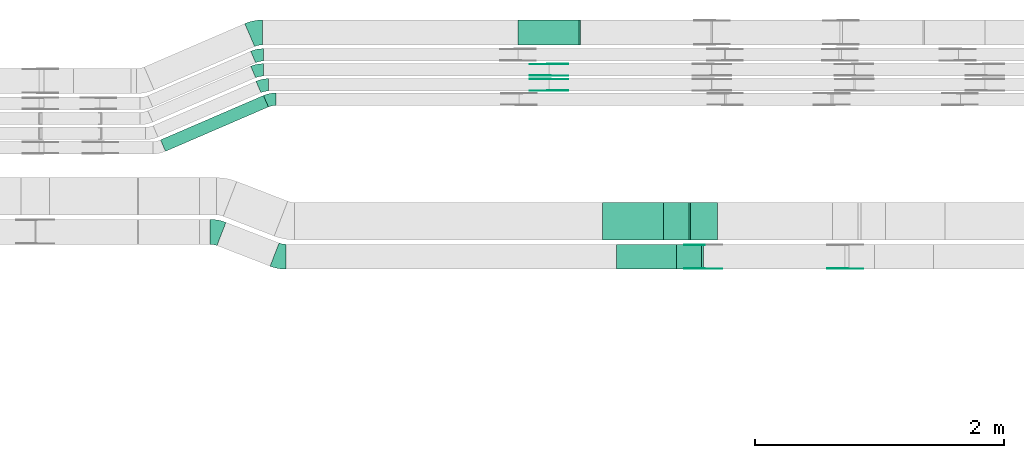
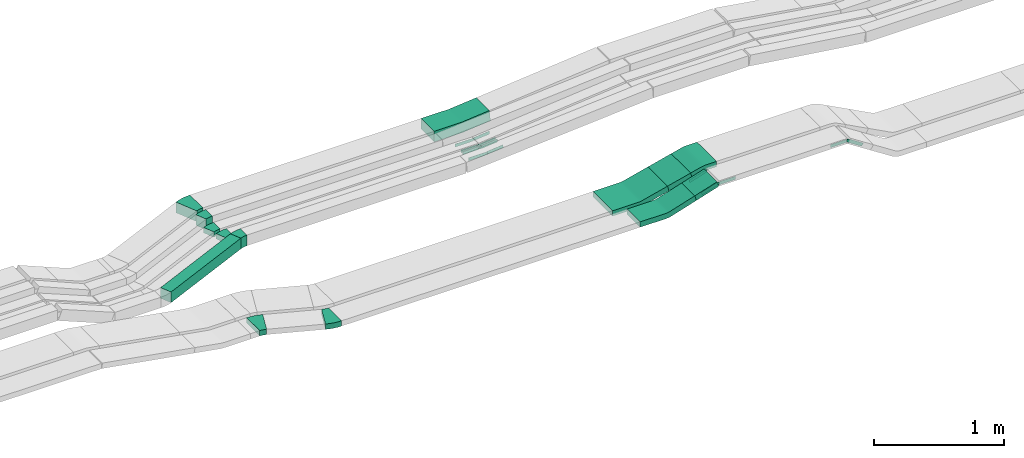
# One storey, part 18 of 31: 24 flow fittings, 3 flow segments.
"""IFC2X3 building model written with IfcOpenShell, lengths in millimetres."""

from ifc_helpers import new_model, entity, si_unit, converted_unit, derived_unit, direction, frame, frame_2d, origin, origin_2d_with_axis, place, context, subcontext, project, spatial, polyline, circle_curve, parameter, trimmed, segment, composite_curve, rectangle, outline, extrude, source, transform, mapped, material, type_object, type_shapes, element, save


model = new_model("IFC2X3")

# Units and contexts
model_context = context("Model", 3, precision=0.01, world=origin(), true_north=direction((6.12303176911189e-17, 1.0)))
body_context = subcontext(model_context, "Body", "Model", "MODEL_VIEW")
ifc_project = project(units=[si_unit("LENGTHUNIT", "METRE", prefix="MILLI"), si_unit("AREAUNIT", "SQUARE_METRE"), si_unit("VOLUMEUNIT", "CUBIC_METRE"), converted_unit("PLANEANGLEUNIT", "DEGREE", entity("IfcRatioMeasure", 0.0174532925199433), si_unit("PLANEANGLEUNIT", "RADIAN"), dimensions=[0, 0, 0, 0, 0, 0, 0]), si_unit("MASSUNIT", "GRAM", prefix="KILO"), derived_unit("MASSDENSITYUNIT", [(si_unit("MASSUNIT", "GRAM", prefix="KILO"), 1), (si_unit("LENGTHUNIT", "METRE"), -3)]), derived_unit("MOMENTOFINERTIAUNIT", [(si_unit("LENGTHUNIT", "METRE"), 4)]), si_unit("TIMEUNIT", "SECOND"), si_unit("FREQUENCYUNIT", "HERTZ"), si_unit("THERMODYNAMICTEMPERATUREUNIT", "DEGREE_CELSIUS"), derived_unit("THERMALTRANSMITTANCEUNIT", [(si_unit("MASSUNIT", "GRAM", prefix="KILO"), 1), (si_unit("THERMODYNAMICTEMPERATUREUNIT", "KELVIN"), -1), (si_unit("TIMEUNIT", "SECOND"), -3)]), derived_unit("VOLUMETRICFLOWRATEUNIT", [(si_unit("LENGTHUNIT", "METRE"), 3), (si_unit("TIMEUNIT", "SECOND"), -1)]), derived_unit("MASSFLOWRATEUNIT", [(si_unit("MASSUNIT", "GRAM", prefix="KILO"), 1), (si_unit("TIMEUNIT", "SECOND"), -1)]), derived_unit("ROTATIONALFREQUENCYUNIT", [(si_unit("TIMEUNIT", "SECOND"), -1)]), si_unit("ELECTRICCURRENTUNIT", "AMPERE"), si_unit("ELECTRICVOLTAGEUNIT", "VOLT"), si_unit("POWERUNIT", "WATT"), si_unit("FORCEUNIT", "NEWTON", prefix="KILO"), si_unit("ILLUMINANCEUNIT", "LUX"), si_unit("LUMINOUSFLUXUNIT", "LUMEN"), si_unit("LUMINOUSINTENSITYUNIT", "CANDELA"), derived_unit("USERDEFINED", [(si_unit("MASSUNIT", "GRAM", prefix="KILO"), -1), (si_unit("LENGTHUNIT", "METRE"), -2), (si_unit("TIMEUNIT", "SECOND"), 3), (si_unit("LUMINOUSFLUXUNIT", "LUMEN"), 1)]), derived_unit("LINEARVELOCITYUNIT", [(si_unit("LENGTHUNIT", "METRE"), 1), (si_unit("TIMEUNIT", "SECOND"), -1)]), si_unit("PRESSUREUNIT", "PASCAL"), derived_unit("USERDEFINED", [(si_unit("LENGTHUNIT", "METRE"), -2), (si_unit("MASSUNIT", "GRAM", prefix="KILO"), 1), (si_unit("TIMEUNIT", "SECOND"), -2)]), derived_unit("LINEARFORCEUNIT", [(si_unit("MASSUNIT", "GRAM", prefix="KILO"), 1), (si_unit("LENGTHUNIT", "METRE"), 1), (si_unit("TIMEUNIT", "SECOND"), -2), (si_unit("LENGTHUNIT", "METRE"), -1)]), derived_unit("PLANARFORCEUNIT", [(si_unit("MASSUNIT", "GRAM", prefix="KILO"), 1), (si_unit("LENGTHUNIT", "METRE"), 1), (si_unit("TIMEUNIT", "SECOND"), -2), (si_unit("LENGTHUNIT", "METRE"), -2)])], contexts=[model_context])

# Site, building, storey
site_placement = place(None, frame((0.0, -0.00077364408347762, 0.0)))
site = spatial("IfcSite", under=ifc_project, at=site_placement, CompositionType="ELEMENT")
building_placement = place(site_placement, origin())
building = spatial("IfcBuilding", under=site, at=building_placement, CompositionType="ELEMENT")
storey_placement = place(building_placement, frame((0.0, 0.0, 15900.0)))
storey = spatial("IfcBuildingStorey", under=building, at=storey_placement, CompositionType="ELEMENT", Elevation=15900.0)

# Flow segments
cable_carrier_segment_type = type_object("IfcCableCarrierSegmentType", PredefinedType="CABLETRAYSEGMENT")
flow_segment_1_placement = place(storey_placement, frame((50303.7519574057, 14200.0255085139, 2726.99262950677)))
element("IfcFlowSegment", 1, at=flow_segment_1_placement, inside=storey, type_object=cable_carrier_segment_type, context=body_context, shape_type="SweptSolid", body=[
    extrude(rectangle(XDim=49.9999999999974, YDim=199.999999999998, at=origin_2d_with_axis()), frame((7.52093070320514, 100.0, 23.8418875376446), z_axis=(0.953675501505744, 0.0, 0.300837228128048), x_axis=(-0.300837228128048, 0.0, 0.953675501505744)), (0.0, 0.0, 1.0), 207.824130212316),
])
flow_segment_2_placement = place(storey_placement, frame((50198.0417260014, 14435.0255085139, 2711.71970550913)))
element("IfcFlowSegment", 2, at=flow_segment_2_placement, inside=storey, type_object=cable_carrier_segment_type, context=body_context, shape_type="SweptSolid", body=[
    extrude(rectangle(XDim=49.9999999999986, YDim=211.330947385812, at=frame_2d((-3.93640675611096e-12, -2.1049828546893e-12), x_axis=(0.0, 1.0))), frame((108.573030414785, 0.0, 49.9446149783502), z_axis=(0.0, 1.0, 0.0), x_axis=(-0.969982804276857, 0.0, -0.243173517076191)), (0.0, 0.0, 1.0), 300.000000000003),
])
flow_segment_3_placement = place(storey_placement, frame((46161.3373267818, 15145.8565107629, 2634.94956318969)))
element("IfcFlowSegment", 3, at=flow_segment_3_placement, inside=storey, type_object=cable_carrier_segment_type, context=body_context, shape_type="SweptSolid", body=[
    extrude(rectangle(XDim=899.544928031165, YDim=100.000000000003, at=frame_2d((-3.15480974677484e-12, 3.69126951227372e-12), x_axis=(1.0, 0.0))), frame((432.765117043787, 224.137398231766, 0.0), z_axis=(0.0, 0.0, 1.0), x_axis=(-0.918134666973488, -0.396268511619941, 0.0)), (0.0, 0.0, 1.0), 99.9999999999989),
])

# Flow fittings
ifc_material_1 = material(Name="G")
cable_carrier_fitting_type_1 = type_object("IfcCableCarrierFittingType", PredefinedType="NOTDEFINED", material=ifc_material_1)
shared_shape_1 = source(origin(), body_context, "Body", "SweptSolid", [
    extrude(outline(composite_curve([segment(trimmed(circle_curve(frame_2d((-44.5901162790698, 0.0), x_axis=(1.0, 0.0)), 12.5), [parameter(90.0000000000007)], [parameter(270.0)], True, "PARAMETER"), True, "CONTINUOUS"), segment(polyline([(-44.5901162790697, -12.5), (-33.0901162790698, -12.5)]), True, "CONTINUOUS"), segment(polyline([(-33.0901162790698, -12.5), (-31.2296511627907, -14.5)]), True, "CONTINUOUS"), segment(polyline([(-31.2296511627907, -14.5), (108.90988372093, -14.5)]), True, "CONTINUOUS"), segment(polyline([(108.90988372093, -14.5), (108.90988372093, 14.5)]), True, "CONTINUOUS"), segment(polyline([(108.90988372093, 14.5), (-31.2296511627907, 14.5)]), True, "CONTINUOUS"), segment(polyline([(-31.2296511627907, 14.5), (-33.0901162790698, 12.5)]), True, "CONTINUOUS"), segment(polyline([(-33.0901162790698, 12.5), (-44.5901162790699, 12.5)]), True, "CONTINUOUS")], self_intersect=False)), frame((44.5901162790698, 0.0, 0.0), z_axis=(0.0, 0.0, -1.0), x_axis=(1.0, 0.0, 0.0)), (0.0, 0.0, -1.0), 2.0),
])
type_shapes(cable_carrier_fitting_type_1, [shared_shape_1])
for number, where, z_axis, x_axis in (
    (4, (49278.6011824917, 15753.9980000417, 2662.24472037609), (0.0, -1.0, 0.0), (0.995479968225886, 0.0, 0.0949717476989256)),
    (5, (49278.6011824917, 15724.918000062, 2662.24472037608), (0.0, 1.0, 0.0), (-1.0, 0.0, 0.0)),
):
    element("IfcFlowFitting", number, at=place(storey_placement, frame(where, z_axis=z_axis, x_axis=x_axis)), inside=storey, type_object=cable_carrier_fitting_type_1, material=ifc_material_1, context=body_context, shape_type="MappedRepresentation", body=[
        mapped(shared_shape_1, transform((0.0, 0.0, 0.0), scale=1.0)),
    ])
cable_carrier_fitting_type_2 = type_object("IfcCableCarrierFittingType", PredefinedType="NOTDEFINED", material=ifc_material_1)
shared_shape_2 = source(origin(), body_context, "Body", "SweptSolid", [
    extrude(outline(composite_curve([segment(trimmed(circle_curve(frame_2d((-44.5901162790697, 0.0), x_axis=(1.0, 0.0)), 12.5), [parameter(90.0000000000007)], [parameter(270.0)], True, "PARAMETER"), True, "CONTINUOUS"), segment(polyline([(-44.5901162790697, -12.5), (-33.0901162790697, -12.5)]), True, "CONTINUOUS"), segment(polyline([(-33.0901162790697, -12.5), (-31.2296511627907, -14.5)]), True, "CONTINUOUS"), segment(polyline([(-31.2296511627907, -14.5), (108.90988372093, -14.5)]), True, "CONTINUOUS"), segment(polyline([(108.90988372093, -14.5), (108.90988372093, 14.5)]), True, "CONTINUOUS"), segment(polyline([(108.90988372093, 14.5), (-31.2296511627907, 14.5)]), True, "CONTINUOUS"), segment(polyline([(-31.2296511627907, 14.5), (-33.0901162790698, 12.5)]), True, "CONTINUOUS"), segment(polyline([(-33.0901162790698, 12.5), (-44.5901162790699, 12.5)]), True, "CONTINUOUS")], self_intersect=False)), frame((44.5901162790697, 0.0, 0.0)), (0.0, 0.0, 1.0), 2.0),
])
type_shapes(cable_carrier_fitting_type_2, [shared_shape_2])
for number, where, z_axis, x_axis in (
    (6, (49278.6011824917, 15844.918000062, 2662.24472037609), (0.0, 1.0, 0.0), (0.995479968225886, 0.0, 0.0949717476989256)),
    (7, (49278.6011824917, 15633.9980000417, 2662.24472037607), (0.0, -1.0, 0.0), (-1.0, 0.0, 0.0)),
    (8, (50514.6820523198, 14204.5655085037, 2815.0), (0.0, -1.0, 0.0), (1.0, 0.0, 0.0)),
    (9, (51665.6593478089, 14204.5655085037, 2815.0), (0.0, -1.0, 0.0), (0.839568506992486, 0.0, -0.543253828395537)),
):
    element("IfcFlowFitting", number, at=place(storey_placement, frame(where, z_axis=z_axis, x_axis=x_axis)), inside=storey, type_object=cable_carrier_fitting_type_2, material=ifc_material_1, context=body_context, shape_type="MappedRepresentation", body=[
        mapped(shared_shape_2, transform((0.0, 0.0, 0.0), scale=1.0)),
    ])
cable_carrier_fitting_type_3 = type_object("IfcCableCarrierFittingType", PredefinedType="NOTDEFINED", material=ifc_material_1)
shared_shape_3 = source(origin(), body_context, "Body", "SweptSolid", [
    extrude(outline(composite_curve([segment(trimmed(circle_curve(frame_2d((-44.5901162790698, 0.0), x_axis=(1.0, 0.0)), 12.5), [parameter(90.0000000000007)], [parameter(270.0)], True, "PARAMETER"), True, "CONTINUOUS"), segment(polyline([(-44.5901162790697, -12.5), (-33.0901162790698, -12.5)]), True, "CONTINUOUS"), segment(polyline([(-33.0901162790698, -12.5), (-31.2296511627907, -14.5)]), True, "CONTINUOUS"), segment(polyline([(-31.2296511627907, -14.5), (108.90988372093, -14.5)]), True, "CONTINUOUS"), segment(polyline([(108.90988372093, -14.5), (108.90988372093, 14.5)]), True, "CONTINUOUS"), segment(polyline([(108.90988372093, 14.5), (-31.2296511627907, 14.5)]), True, "CONTINUOUS"), segment(polyline([(-31.2296511627907, 14.5), (-33.0901162790698, 12.5)]), True, "CONTINUOUS"), segment(polyline([(-33.0901162790698, 12.5), (-44.5901162790699, 12.5)]), True, "CONTINUOUS")], self_intersect=False)), frame((44.5901162790698, 0.0, 0.0), z_axis=(0.0, 0.0, -1.0), x_axis=(1.0, 0.0, 0.0)), (0.0, 0.0, -1.0), 2.0),
])
type_shapes(cable_carrier_fitting_type_3, [shared_shape_3])
for number, where, z_axis, x_axis in (
    (10, (49278.6011824917, 15842.918000062, 2662.2447203761), (0.0, 1.0, 0.0), (-1.0, 0.0, 0.0)),
    (11, (49278.6011824917, 15635.9980000417, 2662.24472037608), (0.0, -1.0, 0.0), (0.995479968225887, 0.0, 0.0949717476989205)),
    (12, (50514.6820523199, 14206.5655085037, 2815.0), (0.0, -1.0, 0.0), (-0.953675501505746, 0.0, -0.300837228128043)),
    (13, (51665.6593478089, 14206.5655085037, 2815.0), (0.0, -1.0, 0.0), (-1.0, 0.0, 0.0)),
):
    element("IfcFlowFitting", number, at=place(storey_placement, frame(where, z_axis=z_axis, x_axis=x_axis)), inside=storey, type_object=cable_carrier_fitting_type_3, material=ifc_material_1, context=body_context, shape_type="MappedRepresentation", body=[
        mapped(shared_shape_3, transform((0.0, 0.0, 0.0), scale=1.0)),
    ])
cable_carrier_fitting_type_4 = type_object("IfcCableCarrierFittingType", PredefinedType="NOTDEFINED", material=ifc_material_1)
shared_shape_4 = source(origin(), body_context, "Body", "SweptSolid", [
    extrude(outline(composite_curve([segment(trimmed(circle_curve(frame_2d((-44.5901162790697, 0.0), x_axis=(1.0, 0.0)), 12.5), [parameter(90.0000000000007)], [parameter(270.0)], True, "PARAMETER"), True, "CONTINUOUS"), segment(polyline([(-44.5901162790697, -12.5), (-33.0901162790697, -12.5)]), True, "CONTINUOUS"), segment(polyline([(-33.0901162790697, -12.5), (-31.2296511627907, -14.5)]), True, "CONTINUOUS"), segment(polyline([(-31.2296511627907, -14.5), (108.90988372093, -14.5)]), True, "CONTINUOUS"), segment(polyline([(108.90988372093, -14.5), (108.90988372093, 14.5)]), True, "CONTINUOUS"), segment(polyline([(108.90988372093, 14.5), (-31.2296511627907, 14.5)]), True, "CONTINUOUS"), segment(polyline([(-31.2296511627907, 14.5), (-33.0901162790698, 12.5)]), True, "CONTINUOUS"), segment(polyline([(-33.0901162790698, 12.5), (-44.5901162790699, 12.5)]), True, "CONTINUOUS")], self_intersect=False)), frame((44.5901162790697, 0.0, 0.0)), (0.0, 0.0, 1.0), 2.0),
])
type_shapes(cable_carrier_fitting_type_4, [shared_shape_4])
for number, where, z_axis, x_axis in (
    (14, (49278.6011824917, 15755.9980000417, 2662.2447203761), (0.0, -1.0, 0.0), (-1.0, 0.0, 0.0)),
    (15, (49278.6011824917, 15722.918000062, 2662.24472037608), (0.0, 1.0, 0.0), (0.995479968225887, 0.0, 0.0949717476989205)),
    (16, (50514.6820523199, 14393.485508524, 2815.0), (0.0, 1.0, 0.0), (-0.953675501505746, 0.0, -0.300837228128043)),
):
    element("IfcFlowFitting", number, at=place(storey_placement, frame(where, z_axis=z_axis, x_axis=x_axis)), inside=storey, type_object=cable_carrier_fitting_type_4, material=ifc_material_1, context=body_context, shape_type="MappedRepresentation", body=[
        mapped(shared_shape_4, transform((0.0, 0.0, 0.0), scale=1.0)),
    ])
ifc_material_2 = material()
cable_carrier_fitting_type_5 = type_object("IfcCableCarrierFittingType", Name="470_DKC_S5_CS 90 internal vertical angle:-", PredefinedType="NOTDEFINED", material=ifc_material_2)
shared_shape_5 = source(origin(), body_context, "Body", "SweptSolid", [
    extrude(outline(composite_curve([segment(polyline([(-247.897285292078, -56.079130384808), (-7.56359020060945, -56.079130384808)]), True, "CONTINUOUS"), segment(trimmed(circle_curve(frame_2d((-7.56359020060981, 158.920869615191), x_axis=(0.0, -1.0)), 214.999999999999), [parameter(0.0)], [parameter(5.4496937226348)], True, "PARAMETER"), True, "CONTINUOUS"), segment(polyline([(12.8553355546568, -55.1073235533738), (252.102714707922, -32.2824124995994)]), True, "CONTINUOUS"), segment(polyline([(252.102714707922, -32.2824124995994), (242.605539938031, 67.2655843229897)]), True, "CONTINUOUS"), segment(polyline([(242.605539938031, 67.2655843229897), (3.35816078476525, 44.4406732692152)]), True, "CONTINUOUS"), segment(trimmed(circle_curve(frame_2d((-7.56359020060981, 158.920869615191), x_axis=(0.0, -1.0)), 114.999999999999), [parameter(0.0)], [parameter(5.4496937226348)], True, "PARAMETER"), False, "CONTINUOUS"), segment(polyline([(-7.56359020060944, 43.9208696151923), (-247.897285292078, 43.9208696151923)]), True, "CONTINUOUS"), segment(polyline([(-247.897285292078, 43.9208696151923), (-247.897285292078, -56.079130384808)]), True, "CONTINUOUS")], self_intersect=False)), frame((-0.289326701500276, 6.07913038480067, -100.0)), (0.0, 0.0, 1.0), 200.0),
])
type_shapes(cable_carrier_fitting_type_5, [shared_shape_5])
flow_fitting_1_placement = place(storey_placement, frame((49278.4870270342, 16099.9939089947, 2685.0), z_axis=(0.0, -1.0, 0.0), x_axis=(1.0, 0.0, 0.0)))
element("IfcFlowFitting", 17, at=flow_fitting_1_placement, inside=storey, type_object=cable_carrier_fitting_type_5, material=ifc_material_2, Name="470_DKC_S5_CS 90 internal vertical angle:-", ObjectType="470_DKC_S5_CS 90 internal vertical angle:-", context=body_context, shape_type="MappedRepresentation", body=[
    mapped(shared_shape_5, transform((0.0, 0.0, 0.0), scale=1.0)),
])
cable_carrier_fitting_type_6 = type_object("IfcCableCarrierFittingType", Name="470_DKC_S5_Variable Angle Elbow 0-45:-", PredefinedType="NOTDEFINED", material=ifc_material_2)
shared_shape_6 = source(origin(), body_context, "Body", "SweptSolid", [
    extrude(outline(composite_curve([segment(polyline([(-46.2053495807307, -108.557423188535), (-45.2053495807293, -108.557423188535)]), True, "CONTINUOUS"), segment(trimmed(circle_curve(frame_2d((-45.2053495807239, 241.442576811465), x_axis=(0.0, -1.0)), 350.0), [parameter(0.0)], [parameter(21.2094457966389)], True, "PARAMETER"), True, "CONTINUOUS"), segment(polyline([(81.4170443255889, -84.8498830484502), (82.3493084966169, -84.4881047801466)]), True, "CONTINUOUS"), segment(polyline([(82.3493084966169, -84.4881047801466), (9.99365483586743, 101.96472942552)]), True, "CONTINUOUS"), segment(polyline([(9.99365483586742, 101.96472942552), (9.0613906648387, 101.602951157216)]), True, "CONTINUOUS"), segment(trimmed(circle_curve(frame_2d((-45.2053495807239, 241.442576811465), x_axis=(0.0, -1.0)), 150.0), [parameter(0.0)], [parameter(21.2094457966389)], True, "PARAMETER"), False, "CONTINUOUS"), segment(polyline([(-45.2053495807259, 91.4425768114652), (-46.2053495807273, 91.4425768114652)]), True, "CONTINUOUS"), segment(polyline([(-46.2053495807273, 91.4425768114652), (-46.2053495807307, -108.557423188535)]), True, "CONTINUOUS")], self_intersect=False)), frame((-1.60220832569917, 8.55742318852739, -25.0)), (0.0, 0.0, 1.0), 50.0000000000005),
])
type_shapes(cable_carrier_fitting_type_6, [shared_shape_6])
for number, where, z_axis, x_axis, name in (
    (18, (46605.5449816896, 14500.0255085139, 2675.0), (0.0, 0.0, 1.0), (-0.932264171028324, 0.361778268303765, 0.0), "470_DKC_S5_Variable Angle Elbow 0-45:-"),
    (19, (47120.9237386279, 14300.0255085139, 2675.0), (0.0, 0.0, 1.0), (0.932264171028321, -0.361778268303775, 0.0), "470_DKC_S5_Variable Angle Elbow 0-45:-"),
):
    element("IfcFlowFitting", number, at=place(storey_placement, frame(where, z_axis=z_axis, x_axis=x_axis)), inside=storey, type_object=cable_carrier_fitting_type_6, material=ifc_material_2, Name=name, ObjectType="470_DKC_S5_Variable Angle Elbow 0-45:-", context=body_context, shape_type="MappedRepresentation", body=[
        mapped(shared_shape_6, transform((0.0, 0.0, 0.0), scale=1.0)),
    ])
cable_carrier_fitting_type_7 = type_object("IfcCableCarrierFittingType", Name="470_DKC_S5_CS 90 internal vertical angle:-", PredefinedType="NOTDEFINED", material=ifc_material_2)
shared_shape_7 = source(origin(), body_context, "Body", "SweptSolid", [
    extrude(outline(composite_curve([segment(polyline([(-248.90921893924, -45.5799867084019), (-18.3889216781085, -45.5799867084019)]), True, "CONTINUOUS"), segment(trimmed(circle_curve(frame_2d((-18.3889216781088, 119.420013291597), x_axis=(0.0, -1.0)), 164.999999999999), [parameter(0.0)], [parameter(17.5078959161392)], True, "PARAMETER"), True, "CONTINUOUS"), segment(polyline([(31.2492209629792, -37.9364444568622), (251.09078106076, 31.4126427983745)]), True, "CONTINUOUS"), segment(polyline([(251.09078106076, 31.4126427983745), (236.048919654369, 79.0964178736658)]), True, "CONTINUOUS"), segment(polyline([(236.048919654369, 79.0964178736658), (16.2073595565887, 9.74733061842903)]), True, "CONTINUOUS"), segment(trimmed(circle_curve(frame_2d((-18.3889216781088, 119.420013291597), x_axis=(0.0, -1.0)), 114.999999999999), [parameter(0.0)], [parameter(17.5078959161392)], True, "PARAMETER"), False, "CONTINUOUS"), segment(polyline([(-18.3889216781085, 4.42001329159838), (-248.90921893924, 4.42001329159839)]), True, "CONTINUOUS"), segment(polyline([(-248.90921893924, 4.42001329159839), (-248.90921893924, -45.5799867084019)]), True, "CONTINUOUS")], self_intersect=False)), frame((-3.16901458377985, 20.5799867083945, -100.0)), (0.0, 0.0, 1.0), 200.0),
])
type_shapes(cable_carrier_fitting_type_7, [shared_shape_7])
flow_fitting_2_placement = place(storey_placement, frame((50070.8720523353, 14300.0255085139, 2675.0), z_axis=(0.0, -1.0, 0.0), x_axis=(1.0, 0.0, 0.0)))
element("IfcFlowFitting", 20, at=flow_fitting_2_placement, inside=storey, type_object=cable_carrier_fitting_type_7, material=ifc_material_2, Name="470_DKC_S5_CS 90 internal vertical angle:-", ObjectType="470_DKC_S5_CS 90 internal vertical angle:-", context=body_context, shape_type="MappedRepresentation", body=[
    mapped(shared_shape_7, transform((0.0, 0.0, 0.0), scale=1.0)),
])
cable_carrier_fitting_type_8 = type_object("IfcCableCarrierFittingType", Name="470_DKC_S5_CS 90 internal vertical angle:-", PredefinedType="NOTDEFINED", material=ifc_material_2)
shared_shape_8 = source(origin(), body_context, "Body", "SweptSolid", [
    extrude(outline(composite_curve([segment(polyline([(-248.712148230997, -41.2929207543232), (-15.2703290008767, -41.2929207543232)]), True, "CONTINUOUS"), segment(trimmed(circle_curve(frame_2d((-15.2703290008769, 123.707079245676), x_axis=(0.0, -1.0)), 164.999999999999), [parameter(0.0)], [parameter(14.0739199213607)], True, "PARAMETER"), True, "CONTINUOUS"), segment(polyline([(24.8533013166727, -36.34008346001), (251.287851769003, 20.4267847548116)]), True, "CONTINUOUS"), segment(polyline([(251.287851769003, 20.4267847548116), (239.1291759152, 68.9259249686564)]), True, "CONTINUOUS"), segment(polyline([(239.1291759152, 68.9259249686564), (12.6946254628697, 12.1590567538348)]), True, "CONTINUOUS"), segment(trimmed(circle_curve(frame_2d((-15.2703290008769, 123.707079245676), x_axis=(0.0, -1.0)), 114.999999999999), [parameter(0.0)], [parameter(14.0739199213607)], True, "PARAMETER"), False, "CONTINUOUS"), segment(polyline([(-15.2703290008767, 8.70707924567706), (-248.712148230997, 8.70707924567708)]), True, "CONTINUOUS"), segment(polyline([(-248.712148230997, 8.70707924567708), (-248.712148230997, -41.2929207543232)]), True, "CONTINUOUS")], self_intersect=False)), frame((-2.01118854167208, 16.292920754316, -150.0)), (0.0, 0.0, 1.0), 300.0),
])
type_shapes(cable_carrier_fitting_type_8, [shared_shape_8])
flow_fitting_3_placement = place(storey_placement, frame((49960.923738628, 14585.0255085139, 2675.0), z_axis=(0.0, -1.0, 0.0), x_axis=(1.0, 0.0, 0.0)))
element("IfcFlowFitting", 21, at=flow_fitting_3_placement, inside=storey, type_object=cable_carrier_fitting_type_8, material=ifc_material_2, Name="470_DKC_S5_CS 90 internal vertical angle:-", ObjectType="470_DKC_S5_CS 90 internal vertical angle:-", context=body_context, shape_type="MappedRepresentation", body=[
    mapped(shared_shape_8, transform((0.0, 0.0, 0.0), scale=1.0)),
])
cable_carrier_fitting_type_9 = type_object("IfcCableCarrierFittingType", Name="470_DKC_S5_Variable Angle Elbow 0-45:-", PredefinedType="NOTDEFINED", material=ifc_material_2)
shared_shape_9 = source(origin(), body_context, "Body", "SweptSolid", [
    extrude(outline(composite_curve([segment(polyline([(-50.5130976192309, -110.332233756216), (-49.5130976192295, -110.332233756216)]), True, "CONTINUOUS"), segment(trimmed(circle_curve(frame_2d((-49.51309761923, 239.667766243783), x_axis=(0.0, -1.0)), 350.0), [parameter(0.0)], [parameter(23.3451113937058)], True, "PARAMETER"), True, "CONTINUOUS"), segment(polyline([(89.1808814477325, -81.6793671969443), (90.0990161147059, -81.2830986853244)]), True, "CONTINUOUS"), segment(polyline([(90.0990161147059, -81.2830986853245), (10.8453137907275, 102.343834709377)]), True, "CONTINUOUS"), segment(polyline([(10.8453137907275, 102.343834709377), (9.92717912375383, 101.947566197757)]), True, "CONTINUOUS"), segment(trimmed(circle_curve(frame_2d((-49.51309761923, 239.667766243783), x_axis=(0.0, -1.0)), 150.0), [parameter(0.0)], [parameter(23.3451113937058)], True, "PARAMETER"), False, "CONTINUOUS"), segment(polyline([(-49.5130976192295, 89.6677662437834), (-50.5130976192309, 89.6677662437834)]), True, "CONTINUOUS"), segment(polyline([(-50.5130976192309, 89.6677662437834), (-50.5130976192309, -110.332233756216)]), True, "CONTINUOUS")], self_intersect=False)), frame((-2.13454193950104, 10.3322337562084, -50.0)), (0.0, 0.0, 1.0), 100.0),
])
type_shapes(cable_carrier_fitting_type_9, [shared_shape_9])
flow_fitting_4_placement = place(storey_placement, frame((46924.900455365, 16099.9939089947, 2685.0), z_axis=(0.0, 0.0, 1.0), x_axis=(-1.0, 0.0, 0.0)))
element("IfcFlowFitting", 22, at=flow_fitting_4_placement, inside=storey, type_object=cable_carrier_fitting_type_9, material=ifc_material_2, Name="470_DKC_S5_Variable Angle Elbow 0-45:-", ObjectType="470_DKC_S5_Variable Angle Elbow 0-45:-", context=body_context, shape_type="MappedRepresentation", body=[
    mapped(shared_shape_9, transform((0.0, 0.0, 0.0), scale=1.0)),
])
cable_carrier_fitting_type_10 = type_object("IfcCableCarrierFittingType", Name="470_DKC_S5_Variable Angle Elbow 0-45:-", PredefinedType="NOTDEFINED", material=ifc_material_2)
shared_shape_10 = source(origin(), body_context, "Body", "SweptSolid", [
    extrude(outline(composite_curve([segment(polyline([(-40.6063848287355, -58.2856004305556), (-39.6063848287342, -58.2856004305556)]), True, "CONTINUOUS"), segment(trimmed(circle_curve(frame_2d((-39.6063848287368, 191.714399569444), x_axis=(0.0, -1.0)), 250.0), [parameter(0.0)], [parameter(23.3451113937074)], True, "PARAMETER"), True, "CONTINUOUS"), segment(polyline([(59.4607430762446, -37.8192671739291), (60.378877743218, -37.4229986623092)]), True, "CONTINUOUS"), segment(polyline([(60.378877743218, -37.4229986623092), (20.7520265812255, 54.3904680350402)]), True, "CONTINUOUS"), segment(polyline([(20.7520265812256, 54.3904680350402), (19.833891914252, 53.9941995234202)]), True, "CONTINUOUS"), segment(trimmed(circle_curve(frame_2d((-39.6063848287368, 191.714399569444), x_axis=(0.0, -1.0)), 150.0), [parameter(0.0)], [parameter(23.3451113937074)], True, "PARAMETER"), False, "CONTINUOUS"), segment(polyline([(-39.6063848287351, 41.7143995694443), (-40.6063848287364, 41.7143995694443)]), True, "CONTINUOUS"), segment(polyline([(-40.6063848287364, 41.7143995694443), (-40.6063848287355, -58.2856004305556)]), True, "CONTINUOUS")], self_intersect=False)), frame((-1.7117268182506, 8.28560043054716, -50.0)), (0.0, 0.0, 1.0), 100.0),
])
type_shapes(cable_carrier_fitting_type_10, [shared_shape_10])
for number, where, z_axis, x_axis, name in (
    (23, (46943.2425387247, 15919.9939089947, 2685.0), (0.0, 0.0, 1.0), (-1.0, 0.0, 0.0), "470_DKC_S5_Variable Angle Elbow 0-45:-"),
    (24, (47045.9078606324, 15564.9939089947, 2684.94956318969), (0.0, 0.0, 1.0), (-1.0, 0.0, 0.0), "470_DKC_S5_Variable Angle Elbow 0-45:-"),
):
    element("IfcFlowFitting", number, at=place(storey_placement, frame(where, z_axis=z_axis, x_axis=x_axis)), inside=storey, type_object=cable_carrier_fitting_type_10, material=ifc_material_2, Name=name, ObjectType="470_DKC_S5_Variable Angle Elbow 0-45:-", context=body_context, shape_type="MappedRepresentation", body=[
        mapped(shared_shape_10, transform((0.0, 0.0, 0.0), scale=1.0)),
    ])
cable_carrier_fitting_type_11 = type_object("IfcCableCarrierFittingType", Name="470_DKC_S5_Variable Angle Elbow 0-45:-", PredefinedType="NOTDEFINED", material=ifc_material_2)
shared_shape_11 = source(origin(), body_context, "Body", "SweptSolid", [
    extrude(outline(composite_curve([segment(polyline([(-40.6063848287359, -58.2856004305552), (-39.6063848287346, -58.2856004305552)]), True, "CONTINUOUS"), segment(trimmed(circle_curve(frame_2d((-39.606384828735, 191.714399569444), x_axis=(0.0, -1.0)), 250.0), [parameter(0.0)], [parameter(23.3451113937073)], True, "PARAMETER"), True, "CONTINUOUS"), segment(polyline([(59.460743076244, -37.8192671739297), (60.3788777432174, -37.4229986623098)]), True, "CONTINUOUS"), segment(polyline([(60.3788777432174, -37.4229986623098), (20.7520265812259, 54.39046803504)]), True, "CONTINUOUS"), segment(polyline([(20.752026581226, 54.39046803504), (19.8338919142524, 53.99419952342)]), True, "CONTINUOUS"), segment(trimmed(circle_curve(frame_2d((-39.606384828735, 191.714399569444), x_axis=(0.0, -1.0)), 150.0), [parameter(0.0)], [parameter(23.3451113937073)], True, "PARAMETER"), False, "CONTINUOUS"), segment(polyline([(-39.6063848287346, 41.7143995694447), (-40.6063848287359, 41.7143995694447)]), True, "CONTINUOUS"), segment(polyline([(-40.6063848287359, 41.7143995694447), (-40.6063848287359, -58.2856004305552)]), True, "CONTINUOUS")], self_intersect=False)), frame((-1.7117268182506, 8.28560043054711, -25.0)), (0.0, 0.0, 1.0), 50.0000000000001),
])
type_shapes(cable_carrier_fitting_type_11, [shared_shape_11])
for number, where, z_axis, x_axis, name in (
    (25, (46943.2425387248, 15799.4580000518, 2662.24472037611), (0.0, 0.0, 1.0), (-1.0, 0.0, 0.0), "470_DKC_S5_Variable Angle Elbow 0-45:-"),
    (26, (46985.9078606336, 15679.4580000518, 2662.24472037609), (0.0, 0.0, 1.0), (-1.0, 0.0, 0.0), "470_DKC_S5_Variable Angle Elbow 0-45:-"),
):
    element("IfcFlowFitting", number, at=place(storey_placement, frame(where, z_axis=z_axis, x_axis=x_axis)), inside=storey, type_object=cable_carrier_fitting_type_11, material=ifc_material_2, Name=name, ObjectType="470_DKC_S5_Variable Angle Elbow 0-45:-", context=body_context, shape_type="MappedRepresentation", body=[
        mapped(shared_shape_11, transform((0.0, 0.0, 0.0), scale=1.0)),
    ])
cable_carrier_fitting_type_12 = type_object("IfcCableCarrierFittingType", Name="470_DKC_S5_CD 90 external vertical angle:-", PredefinedType="NOTDEFINED", material=ifc_material_2)
shared_shape_12 = source(origin(), body_context, "Body", "SweptSolid", [
    extrude(outline(composite_curve([segment(polyline([(-112.660473121997, -33.1483679838594), (-19.3616730733266, -33.1483679838594)]), True, "CONTINUOUS"), segment(trimmed(circle_curve(frame_2d((-19.3616730733269, 156.851632016139), x_axis=(0.0, -1.0)), 189.999999999999), [parameter(0.0)], [parameter(14.0739199213607)], True, "PARAMETER"), True, "CONTINUOUS"), segment(polyline([(26.8412951711242, -27.4451007964686), (117.339526878002, -4.75730344965743)]), True, "CONTINUOUS"), segment(polyline([(117.339526878002, -4.75730344965745), (105.180851024199, 43.7418367641873)]), True, "CONTINUOUS"), segment(polyline([(105.1808510242, 43.7418367641873), (14.6826193173211, 21.0540394173762)]), True, "CONTINUOUS"), segment(trimmed(circle_curve(frame_2d((-19.3616730733269, 156.851632016139), x_axis=(0.0, -1.0)), 139.999999999999), [parameter(0.0)], [parameter(14.0739199213607)], True, "PARAMETER"), False, "CONTINUOUS"), segment(polyline([(-19.3616730733266, 16.8516320161408), (-112.660473121997, 16.8516320161408)]), True, "CONTINUOUS"), segment(polyline([(-112.660473121997, 16.8516320161408), (-112.660473121997, -33.1483679838594)]), True, "CONTINUOUS")], self_intersect=False)), frame((-1.00582974467883, 8.14836798385222, -150.0)), (0.0, 0.0, 1.0), 300.0),
])
type_shapes(cable_carrier_fitting_type_12, [shared_shape_12])
flow_fitting_5_placement = place(storey_placement, frame((50519.3628081105, 14585.0255085139, 2815.0), z_axis=(0.0, 1.0, 0.0), x_axis=(0.969982804276865, 0.0, 0.243173517076161)))
element("IfcFlowFitting", 27, at=flow_fitting_5_placement, inside=storey, type_object=cable_carrier_fitting_type_12, material=ifc_material_2, Name="470_DKC_S5_CD 90 external vertical angle:-", ObjectType="470_DKC_S5_CD 90 external vertical angle:-", context=body_context, shape_type="MappedRepresentation", body=[
    mapped(shared_shape_12, transform((0.0, 0.0, 0.0), scale=1.0)),
])

save(model, "model.ifc")
